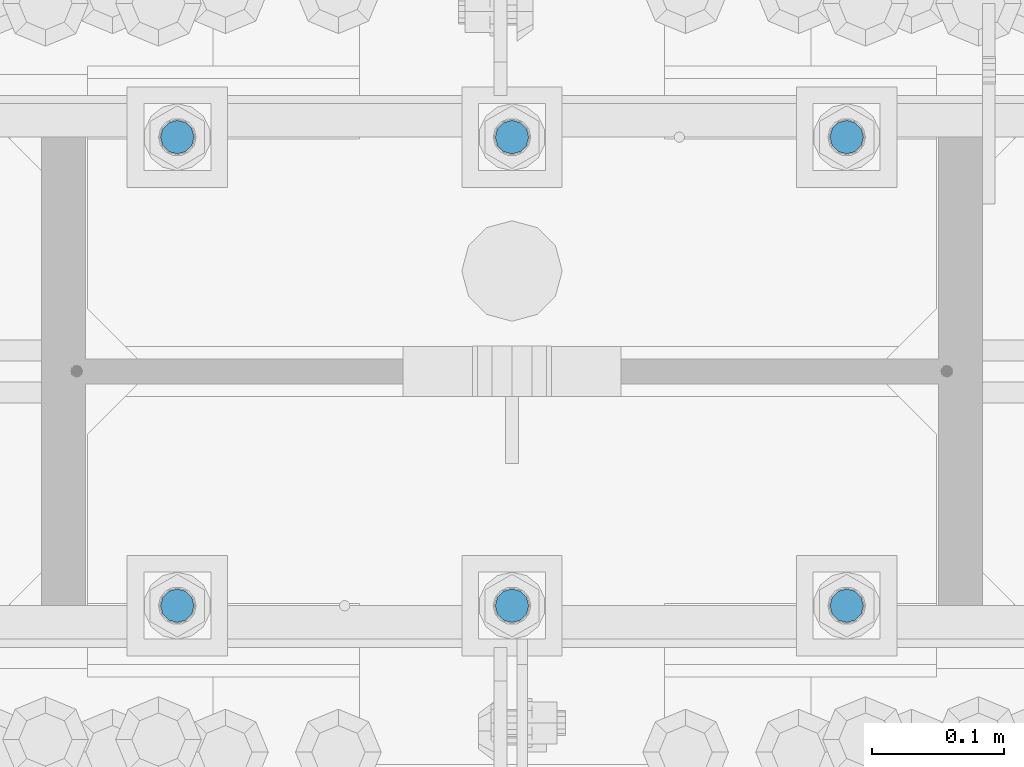
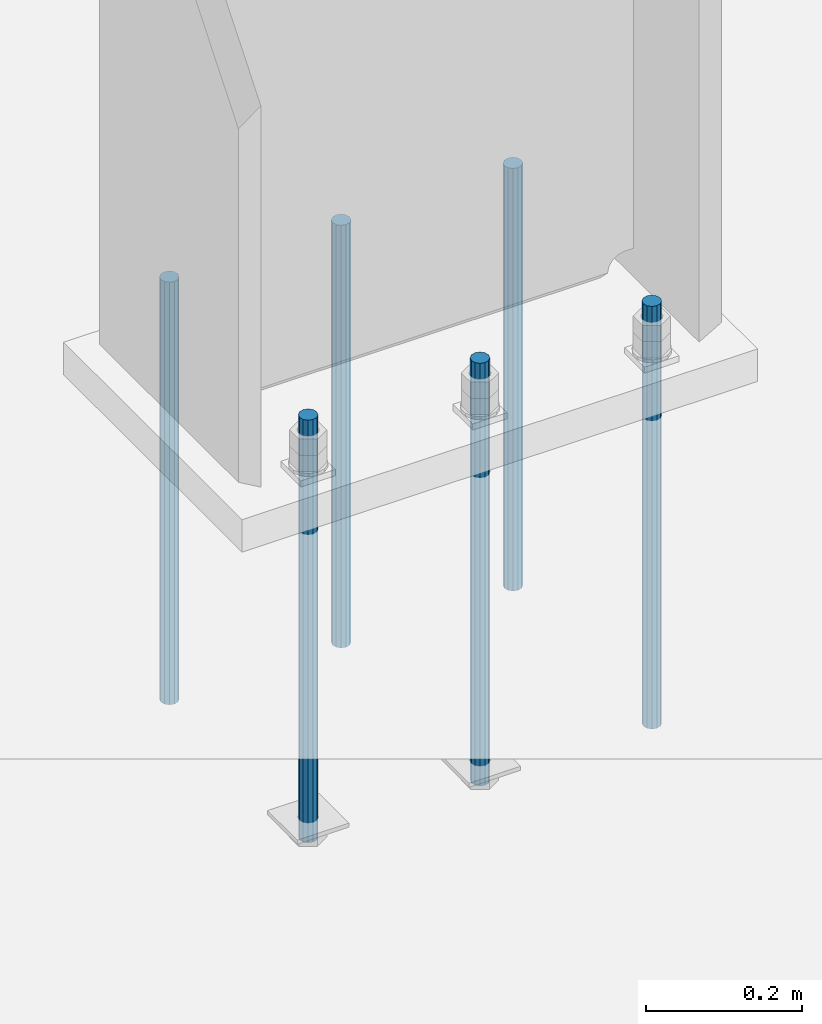
# One storey, part 953 of 1763: 6 columns, 1 element without a shape of its own.
"""IFC2X3 building model written with IfcOpenShell, lengths in millimetres."""

from ifc_helpers import new_model, si_unit, frame, origin_with_axes, place, context, subcontext, project, spatial, faceted_brep, material, type_object, element, aggregate, save


model = new_model("IFC2X3")

# Units and contexts
model_context = context("Model", 3, precision=1e-05, world=origin_with_axes())
body_context = subcontext(model_context, "Body", "Model", "MODEL_VIEW")
ifc_project = project(units=[si_unit("LENGTHUNIT", "METRE", prefix="MILLI"), si_unit("AREAUNIT", "SQUARE_METRE"), si_unit("VOLUMEUNIT", "CUBIC_METRE"), si_unit("MASSUNIT", "GRAM", prefix="KILO"), si_unit("TIMEUNIT", "SECOND"), si_unit("PLANEANGLEUNIT", "RADIAN"), si_unit("SOLIDANGLEUNIT", "STERADIAN"), si_unit("THERMODYNAMICTEMPERATUREUNIT", "DEGREE_CELSIUS"), si_unit("LUMINOUSINTENSITYUNIT", "LUMEN")], contexts=[model_context])

# Site, building, storey
site_placement = place(None, origin_with_axes())
site = spatial("IfcSite", under=ifc_project, at=site_placement, CompositionType="ELEMENT")
building_placement = place(site_placement, origin_with_axes())
building = spatial("IfcBuilding", under=site, at=building_placement, Name="Undefined", CompositionType="ELEMENT")
storey_placement = place(building_placement, origin_with_axes())
storey = spatial("IfcBuildingStorey", under=building, at=storey_placement, Name="Undefined", CompositionType="ELEMENT", Elevation=0.0)

# Assembly, columns
assembly_placement = place(storey_placement, origin_with_axes())
assembly = element("IfcElementAssembly", 1, at=assembly_placement, inside=storey, Name="TEMPLATE", AssemblyPlace="NOTDEFINED", PredefinedType="RIGID_FRAME")
ifc_material = material(Name="STEEL/F1554-55")
column_type = type_object("IfcColumnType", PredefinedType="NOTDEFINED")
column_1_placement = place(assembly_placement, frame((-61340.4372736983, 51943.0, -126.999999999996), z_axis=(1.0, 0.0, 0.0), x_axis=(0.0, 0.0, -1.0)))
column_1 = element("IfcColumn", 2, at=column_1_placement, type_object=column_type, material=ifc_material, Name="ALL THREADED ROD", context=body_context, shape_type="Brep", body=[
    faceted_brep([(0.0, -12.6999999999971, -1.81898940354586e-12), (0.0, -10.9985226280623, -6.35000000000582), (660.399, -10.9985226280623, -6.35000000000582), (660.399, -12.6999999999971, 0.0), (0.0, -6.34999999999854, -10.9985226280696), (660.399, -6.34999999999854, -10.9985226280696), (3.63797880709171e-12, 0.0, -12.6999998092651), (660.399, 0.0, -12.6999999999971), (0.0, 6.34999999999854, -10.9985226280696), (660.399, 6.34999999999854, -10.9985226280696), (0.0, 10.9985226280623, -6.35000000000582), (660.399, 10.9985226280623, -6.35000000000582), (0.0, 12.6999999999971, -1.81898940354586e-12), (660.399, 12.6999999999971, 0.0), (0.0, 10.9985226280623, 6.35000000000582), (660.399, 10.9985226280623, 6.35000000000582), (0.0, 6.34999999999854, 10.9985226280696), (660.399, 6.34999999999854, 10.9985226280696), (-3.63797880709171e-12, 0.0, 12.6999998092651), (660.399, 0.0, 12.6999999999971), (0.0, -6.34999999999854, 10.9985226280696), (660.399, -6.34999999999854, 10.9985226280696), (0.0, -10.9985226280623, 6.35000000000582), (660.399, -10.9985226280623, 6.35000000000582)], [[[0, 1, 2, 3]], [[1, 4, 5, 2]], [[4, 6, 7, 5]], [[6, 8, 9, 7]], [[8, 10, 11, 9]], [[10, 12, 13, 11]], [[12, 14, 15, 13]], [[14, 16, 17, 15]], [[16, 18, 19, 17]], [[18, 20, 21, 19]], [[20, 22, 23, 21]], [[22, 0, 3, 23]], [[5, 7, 9, 11, 13, 15, 17, 19, 21, 23, 3, 2]], [[22, 20, 18, 16, 14, 12, 10, 8, 6, 4, 1, 0]]]),
])
column_2_placement = place(assembly_placement, frame((-61340.4372736983, 52298.6, -126.999999999996), z_axis=(-1.0, 0.0, 0.0), x_axis=(0.0, 0.0, -1.0)))
column_2 = element("IfcColumn", 3, at=column_2_placement, type_object=column_type, material=ifc_material, Name="ALL THREADED ROD", context=body_context, shape_type="Brep", body=[
    faceted_brep([(0.0, -12.6999999999971, -1.81898940354586e-12), (0.0, -10.9985226280623, -6.35000000000582), (660.399, -10.9985226280623, -6.35000000000582), (660.399, -12.6999999999971, 0.0), (0.0, -6.34999999999854, -10.9985226280696), (660.399, -6.34999999999854, -10.9985226280696), (3.63797880709171e-12, 0.0, -12.6999998092651), (660.399, 0.0, -12.6999999999971), (0.0, 6.34999999999854, -10.9985226280696), (660.399, 6.34999999999854, -10.9985226280696), (0.0, 10.9985226280623, -6.35000000000582), (660.399, 10.9985226280623, -6.35000000000582), (0.0, 12.6999999999971, -1.81898940354586e-12), (660.399, 12.6999999999971, 0.0), (0.0, 10.9985226280623, 6.35000000000582), (660.399, 10.9985226280623, 6.35000000000582), (0.0, 6.34999999999854, 10.9985226280696), (660.399, 6.34999999999854, 10.9985226280696), (-3.63797880709171e-12, 0.0, 12.6999998092651), (660.399, 0.0, 12.6999999999971), (0.0, -6.34999999999854, 10.9985226280696), (660.399, -6.34999999999854, 10.9985226280696), (0.0, -10.9985226280623, 6.35000000000582), (660.399, -10.9985226280623, 6.35000000000582)], [[[0, 1, 2, 3]], [[1, 4, 5, 2]], [[4, 6, 7, 5]], [[6, 8, 9, 7]], [[8, 10, 11, 9]], [[10, 12, 13, 11]], [[12, 14, 15, 13]], [[14, 16, 17, 15]], [[16, 18, 19, 17]], [[18, 20, 21, 19]], [[20, 22, 23, 21]], [[22, 0, 3, 23]], [[5, 7, 9, 11, 13, 15, 17, 19, 21, 23, 3, 2]], [[22, 20, 18, 16, 14, 12, 10, 8, 6, 4, 1, 0]]]),
])
column_3_placement = place(assembly_placement, frame((-61594.4372736983, 51943.0, -126.999999999996), z_axis=(1.0, 0.0, 0.0), x_axis=(0.0, 0.0, -1.0)))
column_3 = element("IfcColumn", 4, at=column_3_placement, type_object=column_type, material=ifc_material, Name="ALL THREADED ROD", context=body_context, shape_type="Brep", body=[
    faceted_brep([(0.0, -12.6999999999971, -1.81898940354586e-12), (0.0, -10.9985226280623, -6.35000000000582), (660.399, -10.9985226280623, -6.35000000000582), (660.399, -12.6999999999971, 0.0), (0.0, -6.34999999999854, -10.9985226280696), (660.399, -6.34999999999854, -10.9985226280696), (3.63797880709171e-12, 0.0, -12.6999998092651), (660.399, 0.0, -12.6999999999971), (0.0, 6.34999999999854, -10.9985226280696), (660.399, 6.34999999999854, -10.9985226280696), (0.0, 10.9985226280623, -6.35000000000582), (660.399, 10.9985226280623, -6.35000000000582), (0.0, 12.6999999999971, -1.81898940354586e-12), (660.399, 12.6999999999971, 0.0), (0.0, 10.9985226280623, 6.35000000000582), (660.399, 10.9985226280623, 6.35000000000582), (0.0, 6.34999999999854, 10.9985226280696), (660.399, 6.34999999999854, 10.9985226280696), (-3.63797880709171e-12, 0.0, 12.6999998092651), (660.399, 0.0, 12.6999999999971), (0.0, -6.34999999999854, 10.9985226280696), (660.399, -6.34999999999854, 10.9985226280696), (0.0, -10.9985226280623, 6.35000000000582), (660.399, -10.9985226280623, 6.35000000000582)], [[[0, 1, 2, 3]], [[1, 4, 5, 2]], [[4, 6, 7, 5]], [[6, 8, 9, 7]], [[8, 10, 11, 9]], [[10, 12, 13, 11]], [[12, 14, 15, 13]], [[14, 16, 17, 15]], [[16, 18, 19, 17]], [[18, 20, 21, 19]], [[20, 22, 23, 21]], [[22, 0, 3, 23]], [[5, 7, 9, 11, 13, 15, 17, 19, 21, 23, 3, 2]], [[22, 20, 18, 16, 14, 12, 10, 8, 6, 4, 1, 0]]]),
])
column_4_placement = place(assembly_placement, frame((-61594.4372736983, 52298.6, -126.999999999996), z_axis=(-1.0, 0.0, 0.0), x_axis=(0.0, 0.0, -1.0)))
column_4 = element("IfcColumn", 5, at=column_4_placement, type_object=column_type, material=ifc_material, Name="ALL THREADED ROD", context=body_context, shape_type="Brep", body=[
    faceted_brep([(0.0, -12.6999999999971, -1.81898940354586e-12), (0.0, -10.9985226280623, -6.35000000000582), (660.399, -10.9985226280623, -6.35000000000582), (660.399, -12.6999999999971, 0.0), (0.0, -6.34999999999854, -10.9985226280696), (660.399, -6.34999999999854, -10.9985226280696), (3.63797880709171e-12, 0.0, -12.6999998092651), (660.399, 0.0, -12.6999999999971), (0.0, 6.34999999999854, -10.9985226280696), (660.399, 6.34999999999854, -10.9985226280696), (0.0, 10.9985226280623, -6.35000000000582), (660.399, 10.9985226280623, -6.35000000000582), (0.0, 12.6999999999971, -1.81898940354586e-12), (660.399, 12.6999999999971, 0.0), (0.0, 10.9985226280623, 6.35000000000582), (660.399, 10.9985226280623, 6.35000000000582), (0.0, 6.34999999999854, 10.9985226280696), (660.399, 6.34999999999854, 10.9985226280696), (-3.63797880709171e-12, 0.0, 12.6999998092651), (660.399, 0.0, 12.6999999999971), (0.0, -6.34999999999854, 10.9985226280696), (660.399, -6.34999999999854, 10.9985226280696), (0.0, -10.9985226280623, 6.35000000000582), (660.399, -10.9985226280623, 6.35000000000582)], [[[0, 1, 2, 3]], [[1, 4, 5, 2]], [[4, 6, 7, 5]], [[6, 8, 9, 7]], [[8, 10, 11, 9]], [[10, 12, 13, 11]], [[12, 14, 15, 13]], [[14, 16, 17, 15]], [[16, 18, 19, 17]], [[18, 20, 21, 19]], [[20, 22, 23, 21]], [[22, 0, 3, 23]], [[5, 7, 9, 11, 13, 15, 17, 19, 21, 23, 3, 2]], [[22, 20, 18, 16, 14, 12, 10, 8, 6, 4, 1, 0]]]),
])
column_5_placement = place(assembly_placement, frame((-61848.4372736983, 51943.0, -126.999999999996), z_axis=(1.0, 0.0, 0.0), x_axis=(0.0, 0.0, -1.0)))
column_5 = element("IfcColumn", 6, at=column_5_placement, type_object=column_type, material=ifc_material, Name="ALL THREADED ROD", context=body_context, shape_type="Brep", body=[
    faceted_brep([(0.0, -12.6999999999971, -1.81898940354586e-12), (0.0, -10.9985226280623, -6.35000000000582), (660.399, -10.9985226280623, -6.35000000000582), (660.399, -12.6999999999971, 0.0), (0.0, -6.34999999999854, -10.9985226280696), (660.399, -6.34999999999854, -10.9985226280696), (3.63797880709171e-12, 0.0, -12.6999998092651), (660.399, 0.0, -12.6999999999971), (0.0, 6.34999999999854, -10.9985226280696), (660.399, 6.34999999999854, -10.9985226280696), (0.0, 10.9985226280623, -6.35000000000582), (660.399, 10.9985226280623, -6.35000000000582), (0.0, 12.6999999999971, -1.81898940354586e-12), (660.399, 12.6999999999971, 0.0), (0.0, 10.9985226280623, 6.35000000000582), (660.399, 10.9985226280623, 6.35000000000582), (0.0, 6.34999999999854, 10.9985226280696), (660.399, 6.34999999999854, 10.9985226280696), (-3.63797880709171e-12, 0.0, 12.6999998092651), (660.399, 0.0, 12.6999999999971), (0.0, -6.34999999999854, 10.9985226280696), (660.399, -6.34999999999854, 10.9985226280696), (0.0, -10.9985226280623, 6.35000000000582), (660.399, -10.9985226280623, 6.35000000000582)], [[[0, 1, 2, 3]], [[1, 4, 5, 2]], [[4, 6, 7, 5]], [[6, 8, 9, 7]], [[8, 10, 11, 9]], [[10, 12, 13, 11]], [[12, 14, 15, 13]], [[14, 16, 17, 15]], [[16, 18, 19, 17]], [[18, 20, 21, 19]], [[20, 22, 23, 21]], [[22, 0, 3, 23]], [[5, 7, 9, 11, 13, 15, 17, 19, 21, 23, 3, 2]], [[22, 20, 18, 16, 14, 12, 10, 8, 6, 4, 1, 0]]]),
])
column_6_placement = place(assembly_placement, frame((-61848.4372736983, 52298.6, -126.999999999996), z_axis=(-1.0, 0.0, 0.0), x_axis=(0.0, 0.0, -1.0)))
column_6 = element("IfcColumn", 7, at=column_6_placement, type_object=column_type, material=ifc_material, Name="ALL THREADED ROD", context=body_context, shape_type="Brep", body=[
    faceted_brep([(0.0, -12.6999999999971, -1.81898940354586e-12), (0.0, -10.9985226280623, -6.35000000000582), (660.399, -10.9985226280623, -6.35000000000582), (660.399, -12.6999999999971, 0.0), (0.0, -6.34999999999854, -10.9985226280696), (660.399, -6.34999999999854, -10.9985226280696), (3.63797880709171e-12, 0.0, -12.6999998092651), (660.399, 0.0, -12.6999999999971), (0.0, 6.34999999999854, -10.9985226280696), (660.399, 6.34999999999854, -10.9985226280696), (0.0, 10.9985226280623, -6.35000000000582), (660.399, 10.9985226280623, -6.35000000000582), (0.0, 12.6999999999971, -1.81898940354586e-12), (660.399, 12.6999999999971, 0.0), (0.0, 10.9985226280623, 6.35000000000582), (660.399, 10.9985226280623, 6.35000000000582), (0.0, 6.34999999999854, 10.9985226280696), (660.399, 6.34999999999854, 10.9985226280696), (-3.63797880709171e-12, 0.0, 12.6999998092651), (660.399, 0.0, 12.6999999999971), (0.0, -6.34999999999854, 10.9985226280696), (660.399, -6.34999999999854, 10.9985226280696), (0.0, -10.9985226280623, 6.35000000000582), (660.399, -10.9985226280623, 6.35000000000582)], [[[0, 1, 2, 3]], [[1, 4, 5, 2]], [[4, 6, 7, 5]], [[6, 8, 9, 7]], [[8, 10, 11, 9]], [[10, 12, 13, 11]], [[12, 14, 15, 13]], [[14, 16, 17, 15]], [[16, 18, 19, 17]], [[18, 20, 21, 19]], [[20, 22, 23, 21]], [[22, 0, 3, 23]], [[5, 7, 9, 11, 13, 15, 17, 19, 21, 23, 3, 2]], [[22, 20, 18, 16, 14, 12, 10, 8, 6, 4, 1, 0]]]),
])
aggregate(assembly, [column_1, column_2, column_3, column_4, column_5, column_6])

save(model, "model.ifc")
